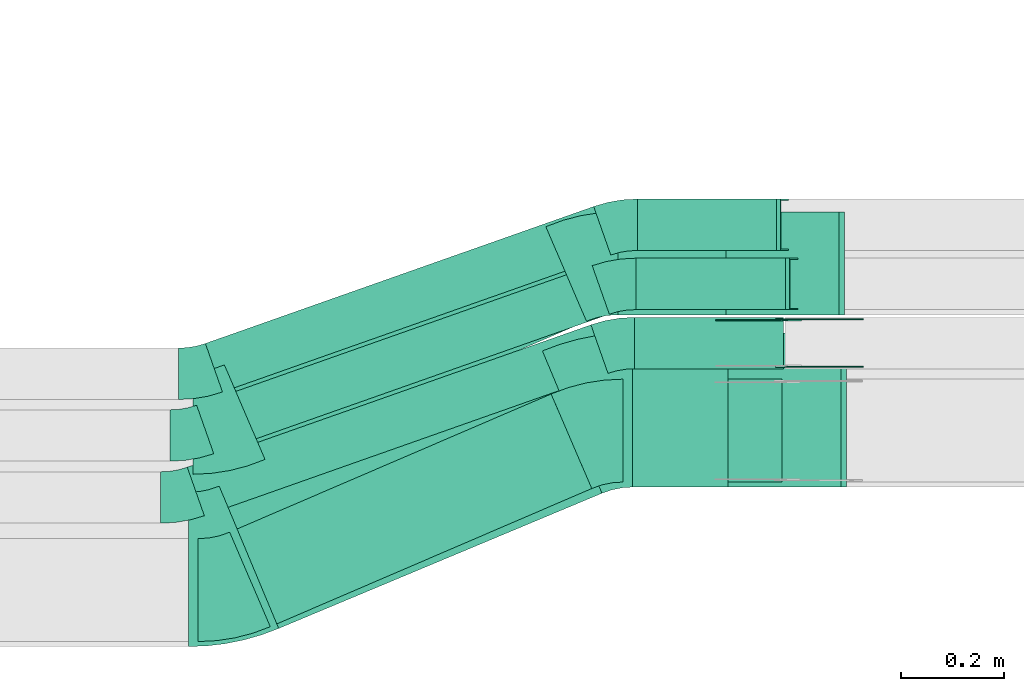
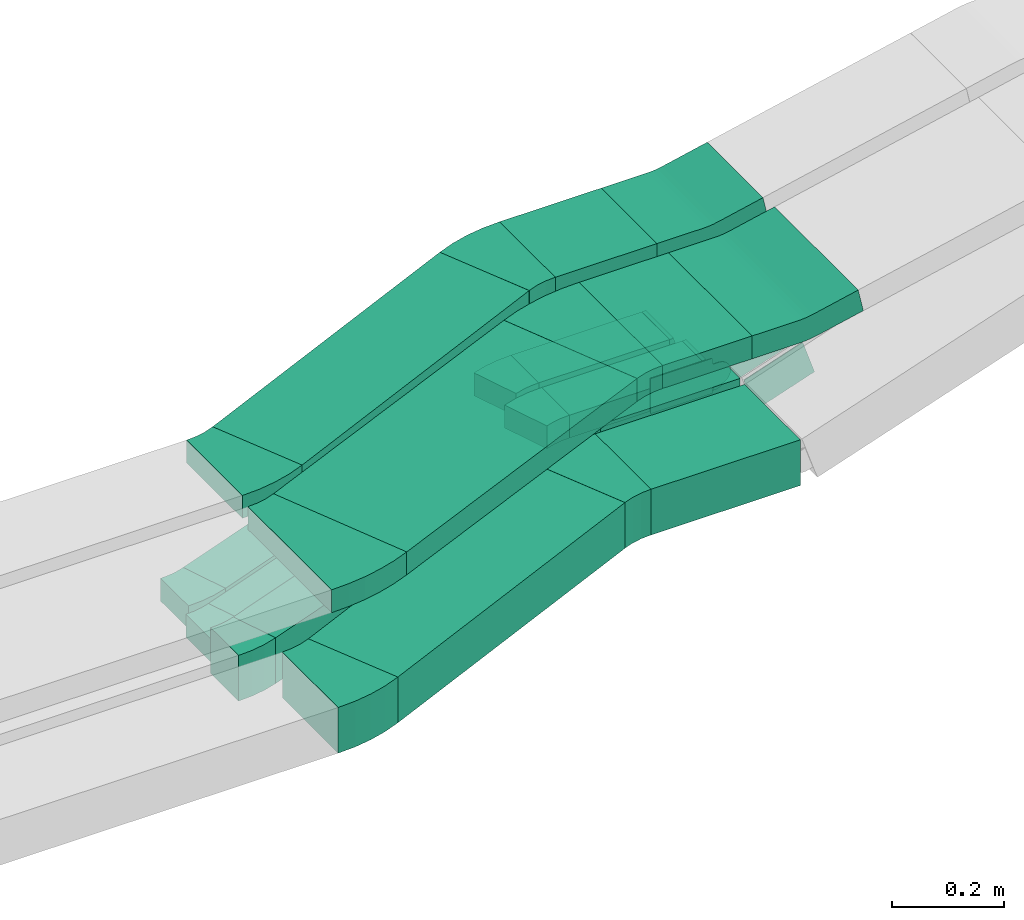
# One storey, part 9 of 28: 19 flow fittings, 12 flow segments.
"""IFC2X3 building model written with IfcOpenShell, lengths in millimetres."""

from ifc_helpers import new_model, entity, si_unit, converted_unit, derived_unit, direction, frame, frame_2d, origin, origin_2d_with_axis, place, context, subcontext, project, spatial, polyline, circle_curve, parameter, trimmed, segment, composite_curve, rectangle, outline, extrude, faceted_brep, source, transform, mapped, material, type_object, type_shapes, element, save


model = new_model("IFC2X3")

# Units and contexts
model_context = context("Model", 3, precision=0.01, world=origin(), true_north=direction((6.12303176911189e-17, 1.0)))
body_context = subcontext(model_context, "Body", "Model", "MODEL_VIEW")
ifc_project = project(units=[si_unit("LENGTHUNIT", "METRE", prefix="MILLI"), si_unit("AREAUNIT", "SQUARE_METRE"), si_unit("VOLUMEUNIT", "CUBIC_METRE"), converted_unit("PLANEANGLEUNIT", "DEGREE", entity("IfcRatioMeasure", 0.0174532925199433), si_unit("PLANEANGLEUNIT", "RADIAN"), dimensions=[0, 0, 0, 0, 0, 0, 0]), si_unit("MASSUNIT", "GRAM", prefix="KILO"), derived_unit("MASSDENSITYUNIT", [(si_unit("MASSUNIT", "GRAM", prefix="KILO"), 1), (si_unit("LENGTHUNIT", "METRE"), -3)]), derived_unit("MOMENTOFINERTIAUNIT", [(si_unit("LENGTHUNIT", "METRE"), 4)]), si_unit("TIMEUNIT", "SECOND"), si_unit("FREQUENCYUNIT", "HERTZ"), si_unit("THERMODYNAMICTEMPERATUREUNIT", "DEGREE_CELSIUS"), derived_unit("THERMALTRANSMITTANCEUNIT", [(si_unit("MASSUNIT", "GRAM", prefix="KILO"), 1), (si_unit("THERMODYNAMICTEMPERATUREUNIT", "KELVIN"), -1), (si_unit("TIMEUNIT", "SECOND"), -3)]), derived_unit("VOLUMETRICFLOWRATEUNIT", [(si_unit("LENGTHUNIT", "METRE"), 3), (si_unit("TIMEUNIT", "SECOND"), -1)]), derived_unit("MASSFLOWRATEUNIT", [(si_unit("MASSUNIT", "GRAM", prefix="KILO"), 1), (si_unit("TIMEUNIT", "SECOND"), -1)]), derived_unit("ROTATIONALFREQUENCYUNIT", [(si_unit("TIMEUNIT", "SECOND"), -1)]), si_unit("ELECTRICCURRENTUNIT", "AMPERE"), si_unit("ELECTRICVOLTAGEUNIT", "VOLT"), si_unit("POWERUNIT", "WATT"), si_unit("FORCEUNIT", "NEWTON", prefix="KILO"), si_unit("ILLUMINANCEUNIT", "LUX"), si_unit("LUMINOUSFLUXUNIT", "LUMEN"), si_unit("LUMINOUSINTENSITYUNIT", "CANDELA"), derived_unit("USERDEFINED", [(si_unit("MASSUNIT", "GRAM", prefix="KILO"), -1), (si_unit("LENGTHUNIT", "METRE"), -2), (si_unit("TIMEUNIT", "SECOND"), 3), (si_unit("LUMINOUSFLUXUNIT", "LUMEN"), 1)]), derived_unit("LINEARVELOCITYUNIT", [(si_unit("LENGTHUNIT", "METRE"), 1), (si_unit("TIMEUNIT", "SECOND"), -1)]), si_unit("PRESSUREUNIT", "PASCAL"), derived_unit("USERDEFINED", [(si_unit("LENGTHUNIT", "METRE"), -2), (si_unit("MASSUNIT", "GRAM", prefix="KILO"), 1), (si_unit("TIMEUNIT", "SECOND"), -2)]), derived_unit("LINEARFORCEUNIT", [(si_unit("MASSUNIT", "GRAM", prefix="KILO"), 1), (si_unit("LENGTHUNIT", "METRE"), 1), (si_unit("TIMEUNIT", "SECOND"), -2), (si_unit("LENGTHUNIT", "METRE"), -1)]), derived_unit("PLANARFORCEUNIT", [(si_unit("MASSUNIT", "GRAM", prefix="KILO"), 1), (si_unit("LENGTHUNIT", "METRE"), 1), (si_unit("TIMEUNIT", "SECOND"), -2), (si_unit("LENGTHUNIT", "METRE"), -2)])], contexts=[model_context])

# Site, building, storey
site_placement = place(None, origin())
site = spatial("IfcSite", under=ifc_project, at=site_placement, CompositionType="ELEMENT")
building_placement = place(site_placement, origin())
building = spatial("IfcBuilding", under=site, at=building_placement, CompositionType="ELEMENT")
storey_placement = place(building_placement, frame((0.0, 0.0, 15900.0)))
storey = spatial("IfcBuildingStorey", under=building, at=storey_placement, CompositionType="ELEMENT", Elevation=15900.0)

# Flow segments
cable_carrier_segment_type = type_object("IfcCableCarrierSegmentType", PredefinedType="CABLETRAYSEGMENT")
flow_segment_1_placement = place(storey_placement, frame((33944.91, 8534.97, 2500.0)))
element("IfcFlowSegment", 1, at=flow_segment_1_placement, inside=storey, type_object=cable_carrier_segment_type, context=body_context, shape_type="SweptSolid", body=[
    extrude(rectangle(XDim=308.884576377895, YDim=200.0, at=origin_2d_with_axis()), frame((154.44, 100.0, 0.0), z_axis=(0.0, 0.0, 1.0), x_axis=(-1.0, 0.0, 0.0)), (0.0, 0.0, 1.0), 100.000000000001),
])
flow_segment_2_placement = place(storey_placement, frame((33934.64, 8860.15, 2820.0)))
element("IfcFlowSegment", 2, at=flow_segment_2_placement, inside=storey, type_object=cable_carrier_segment_type, context=body_context, shape_type="SweptSolid", body=[
    extrude(rectangle(XDim=210.233507475594, YDim=200.0, at=origin_2d_with_axis()), frame((105.12, 100.0, 0.0), z_axis=(0.0, 0.0, 1.0), x_axis=(-1.0, 0.0, 0.0)), (0.0, 0.0, 1.0), 50.0000000000016),
])
flow_segment_3_placement = place(storey_placement, frame((33963.4, 8525.15, 2820.0)))
element("IfcFlowSegment", 3, at=flow_segment_3_placement, inside=storey, type_object=cable_carrier_segment_type, context=body_context, shape_type="SweptSolid", body=[
    extrude(rectangle(XDim=185.088523437471, YDim=300.000000000001, at=origin_2d_with_axis()), frame((92.54, 150.0, 0.0), z_axis=(0.0, 0.0, 1.0), x_axis=(-1.0, 0.0, 0.0)), (0.0, 0.0, 1.0), 50.0000000000016),
])
flow_segment_4_placement = place(storey_placement, frame((33179.89, 8253.8, 2500.0)))
element("IfcFlowSegment", 4, at=flow_segment_4_placement, inside=storey, type_object=cable_carrier_segment_type, context=body_context, shape_type="SweptSolid", body=[
    extrude(rectangle(XDim=680.16852764096, YDim=200.000000000003, at=origin_2d_with_axis()), frame((351.93, 226.16, 0.0), z_axis=(0.0, 0.0, 1.0), x_axis=(0.918736709350663, 0.394870686290481, 0.0)), (0.0, 0.0, 1.0), 99.9999999999989),
])
flow_segment_5_placement = place(storey_placement, frame((33169.62, 8578.99, 2820.0)))
element("IfcFlowSegment", 5, at=flow_segment_5_placement, inside=storey, type_object=cable_carrier_segment_type, context=body_context, shape_type="SweptSolid", body=[
    extrude(rectangle(XDim=680.168527640881, YDim=200.000000000004, at=origin_2d_with_axis()), frame((351.93, 226.16, 0.0), z_axis=(0.0, 0.0, 1.0), x_axis=(0.918736709350649, 0.394870686290513, 0.0)), (0.0, 0.0, 1.0), 50.0000000000016),
])
flow_segment_6_placement = place(storey_placement, frame((33159.52, 8250.38, 2820.0)))
element("IfcFlowSegment", 6, at=flow_segment_6_placement, inside=storey, type_object=cable_carrier_segment_type, context=body_context, shape_type="SweptSolid", body=[
    extrude(rectangle(XDim=681.07290656697, YDim=300.0, at=origin_2d_with_axis()), frame((372.04, 269.77, 0.0), z_axis=(0.0, 0.0, 1.0), x_axis=(0.922573514016603, 0.385821346266711, 0.0)), (0.0, 0.0, 1.0), 50.0000000000016),
])
flow_segment_7_placement = place(storey_placement, frame((33132.68, 8710.07, 2500.0)))
element("IfcFlowSegment", 7, at=flow_segment_7_placement, inside=storey, type_object=cable_carrier_segment_type, context=body_context, shape_type="SweptSolid", body=[
    extrude(rectangle(XDim=800.344538509501, YDim=99.9999999999954, at=origin_2d_with_axis()), frame((394.02, 180.26, 0.0), z_axis=(0.0, 0.0, 1.0), x_axis=(-0.943062738741533, -0.332614898640031, 0.0)), (0.0, 0.0, 1.0), 50.0000000000016),
])
flow_segment_8_placement = place(storey_placement, frame((33115.71, 8590.07, 2500.0)))
element("IfcFlowSegment", 8, at=flow_segment_8_placement, inside=storey, type_object=cable_carrier_segment_type, context=body_context, shape_type="SweptSolid", body=[
    extrude(rectangle(XDim=815.376937901308, YDim=99.9999999999954, at=origin_2d_with_axis()), frame((401.11, 182.76, 0.0), z_axis=(0.0, 0.0, 1.0), x_axis=(0.943062738741534, 0.33261489864003, 0.0)), (0.0, 0.0, 1.0), 50.0000000000016),
])
flow_segment_9_placement = place(storey_placement, frame((33969.76, 8870.15, 2500.0)))
element("IfcFlowSegment", 9, at=flow_segment_9_placement, inside=storey, type_object=cable_carrier_segment_type, context=body_context, shape_type="SweptSolid", body=[
    extrude(rectangle(XDim=290.539792942886, YDim=100.000000000001, at=origin_2d_with_axis()), frame((145.27, 50.0, 0.0), z_axis=(0.0, 0.0, 1.0), x_axis=(-1.0, 0.0, 0.0)), (0.0, 0.0, 1.0), 50.0000000000016),
])
flow_segment_10_placement = place(storey_placement, frame((33097.44, 8469.53, 2500.0)))
element("IfcFlowSegment", 10, at=flow_segment_10_placement, inside=storey, type_object=cable_carrier_segment_type, context=body_context, shape_type="SweptSolid", body=[
    extrude(rectangle(XDim=832.020536746304, YDim=100.0, at=origin_2d_with_axis()), frame((408.95, 185.52, 0.0), z_axis=(0.0, 0.0, 1.0), x_axis=(0.943062738741517, 0.332614898640078, 0.0)), (0.0, 0.0, 1.0), 99.9999999999989),
])
flow_segment_11_placement = place(storey_placement, frame((33967.19, 8755.15, 2500.0)))
element("IfcFlowSegment", 11, at=flow_segment_11_placement, inside=storey, type_object=cable_carrier_segment_type, context=body_context, shape_type="SweptSolid", body=[
    extrude(rectangle(XDim=288.884576377908, YDim=100.000000000001, at=origin_2d_with_axis()), frame((144.44, 50.0, 0.0), z_axis=(0.0, 0.0, 1.0), x_axis=(-1.0, 0.0, 0.0)), (0.0, 0.0, 1.0), 99.9999999999989),
])
flow_segment_12_placement = place(storey_placement, frame((33972.55, 8985.15, 2500.0)))
element("IfcFlowSegment", 12, at=flow_segment_12_placement, inside=storey, type_object=cable_carrier_segment_type, context=body_context, shape_type="SweptSolid", body=[
    extrude(rectangle(XDim=270.781498461428, YDim=99.9999999999989, at=origin_2d_with_axis()), frame((135.39, 50.0, 0.0)), (0.0, 0.0, 1.0), 50.0000000000038),
])

# Flow fittings
ifc_material_1 = material()
cable_carrier_fitting_type_1 = type_object("IfcCableCarrierFittingType", PredefinedType="NOTDEFINED", material=ifc_material_1)
shared_shape_1 = source(origin(), body_context, "Body", "Brep", [
    faceted_brep([(-8.19, 25.0, 50.0), (-8.19, 25.0, -50.0), (-8.19, -25.0, -50.0), (-8.19, -25.0, -47.46), (-8.19, 22.46, -47.46), (-8.19, 22.46, 47.46), (-8.19, -25.0, 47.46), (-8.19, -25.0, 50.0), (-0.21, 26.31, 50.0), (15.74, -21.08, 50.0), (15.74, -21.08, 47.46), (0.6, 23.9, 47.46), (0.6, 23.9, -47.46), (15.74, -21.08, -47.46), (15.74, -21.08, -50.0), (-0.21, 26.31, -50.0), (-4.1, 25.0, 50.0), (-4.1, 25.0, -50.0), (4.1, -25.0, -50.0), (4.1, -25.0, -47.46), (-3.68, 22.46, -47.46), (-3.68, 22.46, 47.46), (4.1, -25.0, 47.46), (4.1, -25.0, 50.0)], [[[0, 1, 2, 3, 4, 5, 6, 7]], [[8, 9, 10, 11, 12, 13, 14, 15]], [[1, 0, 16, 17]], [[2, 1, 17, 15, 14, 18]], [[3, 2, 18, 19]], [[4, 3, 19, 13, 12, 20]], [[5, 4, 20, 21]], [[6, 5, 21, 11, 10, 22]], [[7, 6, 22, 23]], [[0, 7, 23, 9, 8, 16]], [[17, 16, 8, 15]], [[19, 18, 14, 13]], [[21, 20, 12, 11]], [[23, 22, 10, 9]]]),
])
type_shapes(cable_carrier_fitting_type_1, [shared_shape_1])
flow_fitting_1_placement = place(storey_placement, frame((34268.49, 8920.15, 2525.0), z_axis=(0.0, -1.0, 0.0), x_axis=(1.0, 0.0, 0.0)))
element("IfcFlowFitting", 13, at=flow_fitting_1_placement, inside=storey, type_object=cable_carrier_fitting_type_1, material=ifc_material_1, context=body_context, shape_type="MappedRepresentation", body=[
    mapped(shared_shape_1, transform((0.0, 0.0, 0.0), scale=1.0)),
])
cable_carrier_fitting_type_2 = type_object("IfcCableCarrierFittingType", PredefinedType="NOTDEFINED", material=ifc_material_1)
shared_shape_2 = source(origin(), body_context, "Body", "Brep", [
    faceted_brep([(-7.95, 25.0, 50.0), (-7.95, 25.0, -50.0), (-7.95, -25.0, -50.0), (-7.95, -25.0, -47.46), (-7.95, 22.46, -47.46), (-7.95, 22.46, 47.46), (-7.95, -25.0, 47.46), (-7.95, -25.0, 50.0), (-0.2, 26.23, 50.0), (15.31, -21.3, 50.0), (15.31, -21.3, 47.46), (0.59, 23.82, 47.46), (0.59, 23.82, -47.46), (15.31, -21.3, -47.46), (15.31, -21.3, -50.0), (-0.2, 26.23, -50.0), (-3.97, 25.0, 50.0), (-3.97, 25.0, -50.0), (3.97, -25.0, -50.0), (3.97, -25.0, -47.46), (-3.57, 22.46, -47.46), (-3.57, 22.46, 47.46), (3.97, -25.0, 47.46), (3.97, -25.0, 50.0)], [[[0, 1, 2, 3, 4, 5, 6, 7]], [[8, 9, 10, 11, 12, 13, 14, 15]], [[1, 0, 16, 17]], [[2, 1, 17, 15, 14, 18]], [[3, 2, 18, 19]], [[4, 3, 19, 13, 12, 20]], [[5, 4, 20, 21]], [[6, 5, 21, 11, 10, 22]], [[7, 6, 22, 23]], [[0, 7, 23, 9, 8, 16]], [[17, 16, 8, 15]], [[19, 18, 14, 13]], [[21, 20, 12, 11]], [[23, 22, 10, 9]]]),
])
type_shapes(cable_carrier_fitting_type_2, [shared_shape_2])
flow_fitting_2_placement = place(storey_placement, frame((34251.28, 9035.15, 2525.0), z_axis=(0.0, -1.0, 0.0), x_axis=(1.0, 0.0, 0.0)))
element("IfcFlowFitting", 14, at=flow_fitting_2_placement, inside=storey, type_object=cable_carrier_fitting_type_2, material=ifc_material_1, context=body_context, shape_type="MappedRepresentation", body=[
    mapped(shared_shape_2, transform((0.0, 0.0, 0.0), scale=1.0)),
])
cable_carrier_fitting_type_3 = type_object("IfcCableCarrierFittingType", Name="470_DKC_S5_Variable Angle Elbow 0-45:-", PredefinedType="NOTDEFINED", material=ifc_material_1)
shared_shape_3 = source(origin(), body_context, "Body", "SweptSolid", [
    extrude(outline(composite_curve([segment(polyline([(-50.34, -110.26), (-49.34, -110.26)]), True, "CONTINUOUS"), segment(trimmed(circle_curve(frame_2d((-49.34, 239.74), x_axis=(0.0, -1.0)), 350.0), [parameter(0.0)], [parameter(23.2579093419499)], True, "PARAMETER"), True, "CONTINUOUS"), segment(polyline([(88.87, -81.81), (89.78, -81.42)]), True, "CONTINUOUS"), segment(polyline([(89.78, -81.42), (10.81, 102.33)]), True, "CONTINUOUS"), segment(polyline([(10.81, 102.33), (9.89, 101.93)]), True, "CONTINUOUS"), segment(trimmed(circle_curve(frame_2d((-49.34, 239.74), x_axis=(0.0, -1.0)), 150.0), [parameter(0.0)], [parameter(23.2579093419499)], True, "PARAMETER"), False, "CONTINUOUS"), segment(polyline([(-49.34, 89.74), (-50.34, 89.74)]), True, "CONTINUOUS"), segment(polyline([(-50.34, 89.74), (-50.34, -110.26)]), True, "CONTINUOUS")], self_intersect=False)), frame((-2.11, 10.26, -50.0)), (0.0, 0.0, 1.0), 100.0),
])
type_shapes(cable_carrier_fitting_type_3, [shared_shape_3])
flow_fitting_3_placement = place(storey_placement, frame((33171.19, 8324.97, 2550.0)))
element("IfcFlowFitting", 15, at=flow_fitting_3_placement, inside=storey, type_object=cable_carrier_fitting_type_3, material=ifc_material_1, Name="470_DKC_S5_Variable Angle Elbow 0-45:-", ObjectType="470_DKC_S5_Variable Angle Elbow 0-45:-", context=body_context, shape_type="MappedRepresentation", body=[
    mapped(shared_shape_3, transform((0.0, 0.0, 0.0), scale=1.0)),
])
flow_fitting_4_placement = place(storey_placement, frame((33892.46, 8634.97, 2550.0), z_axis=(0.0, 0.0, 1.0), x_axis=(-1.0, 0.0, 0.0)))
element("IfcFlowFitting", 16, at=flow_fitting_4_placement, inside=storey, type_object=cable_carrier_fitting_type_3, material=ifc_material_1, Name="470_DKC_S5_Variable Angle Elbow 0-45:-", ObjectType="470_DKC_S5_Variable Angle Elbow 0-45:-", context=body_context, shape_type="MappedRepresentation", body=[
    mapped(shared_shape_3, transform((0.0, 0.0, 0.0), scale=1.0)),
])
cable_carrier_fitting_type_4 = type_object("IfcCableCarrierFittingType", Name="470_DKC_S5_Variable Angle Elbow 0-45:-", PredefinedType="NOTDEFINED", material=ifc_material_1)
shared_shape_4 = source(origin(), body_context, "Body", "SweptSolid", [
    extrude(outline(composite_curve([segment(polyline([(-50.34, -110.26), (-49.34, -110.26)]), True, "CONTINUOUS"), segment(trimmed(circle_curve(frame_2d((-49.34, 239.74), x_axis=(0.0, -1.0)), 350.0), [parameter(0.0)], [parameter(23.2579093419518)], True, "PARAMETER"), True, "CONTINUOUS"), segment(polyline([(88.87, -81.81), (89.78, -81.42)]), True, "CONTINUOUS"), segment(polyline([(89.78, -81.42), (10.81, 102.33)]), True, "CONTINUOUS"), segment(polyline([(10.81, 102.33), (9.89, 101.93)]), True, "CONTINUOUS"), segment(trimmed(circle_curve(frame_2d((-49.34, 239.74), x_axis=(0.0, -1.0)), 150.0), [parameter(0.0)], [parameter(23.2579093419518)], True, "PARAMETER"), False, "CONTINUOUS"), segment(polyline([(-49.34, 89.74), (-50.34, 89.74)]), True, "CONTINUOUS"), segment(polyline([(-50.34, 89.74), (-50.34, -110.26)]), True, "CONTINUOUS")], self_intersect=False)), frame((-2.11, 10.26, -25.0)), (0.0, 0.0, 1.0), 50.0000000000006),
])
type_shapes(cable_carrier_fitting_type_4, [shared_shape_4])
flow_fitting_5_placement = place(storey_placement, frame((33160.92, 8650.15, 2845.0)))
element("IfcFlowFitting", 17, at=flow_fitting_5_placement, inside=storey, type_object=cable_carrier_fitting_type_4, material=ifc_material_1, Name="470_DKC_S5_Variable Angle Elbow 0-45:-", ObjectType="470_DKC_S5_Variable Angle Elbow 0-45:-", context=body_context, shape_type="MappedRepresentation", body=[
    mapped(shared_shape_4, transform((0.0, 0.0, 0.0), scale=1.0)),
])
flow_fitting_6_placement = place(storey_placement, frame((33882.19, 8960.15, 2845.0), z_axis=(0.0, 0.0, 1.0), x_axis=(-1.0, 0.0, 0.0)))
element("IfcFlowFitting", 18, at=flow_fitting_6_placement, inside=storey, type_object=cable_carrier_fitting_type_4, material=ifc_material_1, Name="470_DKC_S5_Variable Angle Elbow 0-45:-", ObjectType="470_DKC_S5_Variable Angle Elbow 0-45:-", context=body_context, shape_type="MappedRepresentation", body=[
    mapped(shared_shape_4, transform((0.0, 0.0, 0.0), scale=1.0)),
])
cable_carrier_fitting_type_5 = type_object("IfcCableCarrierFittingType", Name="470_DKC_S5_Variable Angle Elbow 0-45:-", PredefinedType="NOTDEFINED", material=ifc_material_1)
shared_shape_5 = source(origin(), body_context, "Body", "SweptSolid", [
    extrude(outline(composite_curve([segment(polyline([(-58.85, -161.71), (-57.85, -161.71)]), True, "CONTINUOUS"), segment(trimmed(circle_curve(frame_2d((-57.85, 288.29), x_axis=(0.0, -1.0)), 450.0), [parameter(0.0)], [parameter(22.6947399098988)], True, "PARAMETER"), True, "CONTINUOUS"), segment(polyline([(115.77, -126.87), (116.69, -126.48)]), True, "CONTINUOUS"), segment(polyline([(116.69, -126.48), (0.94, 150.29)]), True, "CONTINUOUS"), segment(polyline([(0.94, 150.29), (0.02, 149.9)]), True, "CONTINUOUS"), segment(trimmed(circle_curve(frame_2d((-57.85, 288.29), x_axis=(0.0, -1.0)), 150.0), [parameter(0.0)], [parameter(22.6947399098988)], True, "PARAMETER"), False, "CONTINUOUS"), segment(polyline([(-57.85, 138.29), (-58.85, 138.29)]), True, "CONTINUOUS"), segment(polyline([(-58.85, 138.29), (-58.85, -161.71)]), True, "CONTINUOUS")], self_intersect=False)), frame((-2.35, 11.71, -25.0)), (0.0, 0.0, 1.0), 49.9999999999992),
])
type_shapes(cable_carrier_fitting_type_5, [shared_shape_5])
flow_fitting_7_placement = place(storey_placement, frame((33160.92, 8365.15, 2845.0)))
element("IfcFlowFitting", 19, at=flow_fitting_7_placement, inside=storey, type_object=cable_carrier_fitting_type_5, material=ifc_material_1, Name="470_DKC_S5_Variable Angle Elbow 0-45:-", ObjectType="470_DKC_S5_Variable Angle Elbow 0-45:-", context=body_context, shape_type="MappedRepresentation", body=[
    mapped(shared_shape_5, transform((0.0, 0.0, 0.0), scale=1.0)),
])
flow_fitting_8_placement = place(storey_placement, frame((33902.19, 8675.15, 2845.0), z_axis=(0.0, 0.0, 1.0), x_axis=(-1.0, 0.0, 0.0)))
element("IfcFlowFitting", 20, at=flow_fitting_8_placement, inside=storey, type_object=cable_carrier_fitting_type_5, material=ifc_material_1, Name="470_DKC_S5_Variable Angle Elbow 0-45:-", ObjectType="470_DKC_S5_Variable Angle Elbow 0-45:-", context=body_context, shape_type="MappedRepresentation", body=[
    mapped(shared_shape_5, transform((0.0, 0.0, 0.0), scale=1.0)),
])
cable_carrier_fitting_type_6 = type_object("IfcCableCarrierFittingType", Name="470_DKC_S5_Variable Angle Elbow 0-45:-", PredefinedType="NOTDEFINED", material=ifc_material_1)
shared_shape_6 = source(origin(), body_context, "Body", "SweptSolid", [
    extrude(outline(composite_curve([segment(polyline([(-34.25, -55.78), (-33.25, -55.78)]), True, "CONTINUOUS"), segment(trimmed(circle_curve(frame_2d((-33.25, 194.22), x_axis=(0.0, -1.0)), 250.0), [parameter(0.0)], [parameter(19.4275662628412)], True, "PARAMETER"), True, "CONTINUOUS"), segment(polyline([(49.91, -41.54), (50.85, -41.21)]), True, "CONTINUOUS"), segment(polyline([(50.85, -41.21), (17.59, 53.1)]), True, "CONTINUOUS"), segment(polyline([(17.59, 53.1), (16.64, 52.76)]), True, "CONTINUOUS"), segment(trimmed(circle_curve(frame_2d((-33.25, 194.22), x_axis=(0.0, -1.0)), 150.0), [parameter(0.0)], [parameter(19.4275662628412)], True, "PARAMETER"), False, "CONTINUOUS"), segment(polyline([(-33.25, 44.22), (-34.25, 44.22)]), True, "CONTINUOUS"), segment(polyline([(-34.25, 44.22), (-34.25, -55.78)]), True, "CONTINUOUS")], self_intersect=False)), frame((-0.99, 5.78, -25.0)), (0.0, 0.0, 1.0), 50.0000000000001),
])
type_shapes(cable_carrier_fitting_type_6, [shared_shape_6])
flow_fitting_9_placement = place(storey_placement, frame((33937.31, 9035.15, 2525.0), z_axis=(0.0, 0.0, 1.0), x_axis=(-1.0, 0.0, 0.0)))
element("IfcFlowFitting", 21, at=flow_fitting_9_placement, inside=storey, type_object=cable_carrier_fitting_type_6, material=ifc_material_1, Name="470_DKC_S5_Variable Angle Elbow 0-45:-", ObjectType="470_DKC_S5_Variable Angle Elbow 0-45:-", context=body_context, shape_type="MappedRepresentation", body=[
    mapped(shared_shape_6, transform((0.0, 0.0, 0.0), scale=1.0)),
])
for number, where, name in (
    (22, (33116.08, 8745.5, 2525.0), "470_DKC_S5_Variable Angle Elbow 0-45:-"),
    (23, (33099.11, 8625.5, 2525.0), "470_DKC_S5_Variable Angle Elbow 0-45:-"),
):
    element("IfcFlowFitting", number, at=place(storey_placement, frame(where)), inside=storey, type_object=cable_carrier_fitting_type_6, material=ifc_material_1, Name=name, ObjectType="470_DKC_S5_Variable Angle Elbow 0-45:-", context=body_context, shape_type="MappedRepresentation", body=[
        mapped(shared_shape_6, transform((0.0, 0.0, 0.0), scale=1.0)),
    ])
flow_fitting_10_placement = place(storey_placement, frame((33934.52, 8920.15, 2525.0), z_axis=(0.0, 0.0, 1.0), x_axis=(-1.0, 0.0, 0.0)))
element("IfcFlowFitting", 24, at=flow_fitting_10_placement, inside=storey, type_object=cable_carrier_fitting_type_6, material=ifc_material_1, Name="470_DKC_S5_Variable Angle Elbow 0-45:-", ObjectType="470_DKC_S5_Variable Angle Elbow 0-45:-", context=body_context, shape_type="MappedRepresentation", body=[
    mapped(shared_shape_6, transform((0.0, 0.0, 0.0), scale=1.0)),
])
cable_carrier_fitting_type_7 = type_object("IfcCableCarrierFittingType", Name="470_DKC_S5_Variable Angle Elbow 0-45:-", PredefinedType="NOTDEFINED", material=ifc_material_1)
shared_shape_7 = source(origin(), body_context, "Body", "SweptSolid", [
    extrude(outline(composite_curve([segment(polyline([(-34.25, -55.78), (-33.25, -55.78)]), True, "CONTINUOUS"), segment(trimmed(circle_curve(frame_2d((-33.25, 194.22), x_axis=(0.0, -1.0)), 250.0), [parameter(0.0)], [parameter(19.4275662628425)], True, "PARAMETER"), True, "CONTINUOUS"), segment(polyline([(49.91, -41.54), (50.85, -41.21)]), True, "CONTINUOUS"), segment(polyline([(50.85, -41.21), (17.59, 53.1)]), True, "CONTINUOUS"), segment(polyline([(17.59, 53.1), (16.64, 52.76)]), True, "CONTINUOUS"), segment(trimmed(circle_curve(frame_2d((-33.25, 194.22), x_axis=(0.0, -1.0)), 150.0), [parameter(0.0)], [parameter(19.4275662628425)], True, "PARAMETER"), False, "CONTINUOUS"), segment(polyline([(-33.25, 44.22), (-34.25, 44.22)]), True, "CONTINUOUS"), segment(polyline([(-34.25, 44.22), (-34.25, -55.78)]), True, "CONTINUOUS")], self_intersect=False)), frame((-0.99, 5.78, -50.0)), (0.0, 0.0, 1.0), 100.0),
])
type_shapes(cable_carrier_fitting_type_7, [shared_shape_7])
flow_fitting_11_placement = place(storey_placement, frame((33080.84, 8504.97, 2550.0)))
element("IfcFlowFitting", 25, at=flow_fitting_11_placement, inside=storey, type_object=cable_carrier_fitting_type_7, material=ifc_material_1, Name="470_DKC_S5_Variable Angle Elbow 0-45:-", ObjectType="470_DKC_S5_Variable Angle Elbow 0-45:-", context=body_context, shape_type="MappedRepresentation", body=[
    mapped(shared_shape_7, transform((0.0, 0.0, 0.0), scale=1.0)),
])
flow_fitting_12_placement = place(storey_placement, frame((33931.95, 8805.15, 2550.0), z_axis=(0.0, 0.0, 1.0), x_axis=(-1.0, 0.0, 0.0)))
element("IfcFlowFitting", 26, at=flow_fitting_12_placement, inside=storey, type_object=cable_carrier_fitting_type_7, material=ifc_material_1, Name="470_DKC_S5_Variable Angle Elbow 0-45:-", ObjectType="470_DKC_S5_Variable Angle Elbow 0-45:-", context=body_context, shape_type="MappedRepresentation", body=[
    mapped(shared_shape_7, transform((0.0, 0.0, 0.0), scale=1.0)),
])
cable_carrier_fitting_type_8 = type_object("IfcCableCarrierFittingType", Name="470_DKC_S5_CD 90 external vertical angle:-", PredefinedType="NOTDEFINED", material=ifc_material_1)
shared_shape_8 = source(origin(), body_context, "Body", "SweptSolid", [
    extrude(outline(composite_curve([segment(polyline([(-112.89, -31.98), (-16.98, -31.98)]), True, "CONTINUOUS"), segment(trimmed(circle_curve(frame_2d((-16.98, 158.02), x_axis=(0.0, -1.0)), 189.999999999999), [parameter(0.0)], [parameter(12.2682836771792)], True, "PARAMETER"), True, "CONTINUOUS"), segment(polyline([(23.39, -27.64), (117.11, -7.26)]), True, "CONTINUOUS"), segment(polyline([(117.11, -7.26), (106.48, 41.6)]), True, "CONTINUOUS"), segment(polyline([(106.48, 41.6), (12.77, 21.22)]), True, "CONTINUOUS"), segment(trimmed(circle_curve(frame_2d((-16.98, 158.02), x_axis=(0.0, -1.0)), 139.999999999999), [parameter(0.0)], [parameter(12.2682836771792)], True, "PARAMETER"), False, "CONTINUOUS"), segment(polyline([(-16.98, 18.02), (-112.89, 18.02)]), True, "CONTINUOUS"), segment(polyline([(-112.89, 18.02), (-112.89, -31.98)]), True, "CONTINUOUS")], self_intersect=False)), frame((-0.75, 6.98, -150.0)), (0.0, 0.0, 1.0), 300.0),
])
type_shapes(cable_carrier_fitting_type_8, [shared_shape_8])
flow_fitting_13_placement = place(storey_placement, frame((34262.13, 8675.15, 2845.0), z_axis=(0.0, -1.0, 0.0), x_axis=(1.0, 0.0, 0.0)))
element("IfcFlowFitting", 27, at=flow_fitting_13_placement, inside=storey, type_object=cable_carrier_fitting_type_8, material=ifc_material_1, Name="470_DKC_S5_CD 90 external vertical angle:-", ObjectType="470_DKC_S5_CD 90 external vertical angle:-", context=body_context, shape_type="MappedRepresentation", body=[
    mapped(shared_shape_8, transform((0.0, 0.0, 0.0), scale=1.0)),
])
cable_carrier_fitting_type_9 = type_object("IfcCableCarrierFittingType", Name="470_DKC_S5_CD 90 external vertical angle:-", PredefinedType="NOTDEFINED", material=ifc_material_1)
shared_shape_9 = source(origin(), body_context, "Body", "SweptSolid", [
    extrude(outline(composite_curve([segment(polyline([(-112.89, -31.99), (-17.01, -31.99)]), True, "CONTINUOUS"), segment(trimmed(circle_curve(frame_2d((-17.01, 158.01), x_axis=(0.0, -1.0)), 189.999999999999), [parameter(0.0)], [parameter(12.2917958116951)], True, "PARAMETER"), True, "CONTINUOUS"), segment(polyline([(23.44, -27.64), (117.11, -7.23)]), True, "CONTINUOUS"), segment(polyline([(117.11, -7.23), (106.47, 41.63)]), True, "CONTINUOUS"), segment(polyline([(106.47, 41.63), (12.79, 21.22)]), True, "CONTINUOUS"), segment(trimmed(circle_curve(frame_2d((-17.01, 158.01), x_axis=(0.0, -1.0)), 139.999999999999), [parameter(0.0)], [parameter(12.2917958116951)], True, "PARAMETER"), False, "CONTINUOUS"), segment(polyline([(-17.01, 18.01), (-112.89, 18.01)]), True, "CONTINUOUS"), segment(polyline([(-112.89, 18.01), (-112.89, -31.99)]), True, "CONTINUOUS")], self_intersect=False)), frame((-0.75, 6.99, -100.0)), (0.0, 0.0, 1.0), 200.0),
])
type_shapes(cable_carrier_fitting_type_9, [shared_shape_9])
flow_fitting_14_placement = place(storey_placement, frame((34258.52, 8960.15, 2845.0), z_axis=(0.0, -1.0, 0.0), x_axis=(1.0, 0.0, 0.0)))
element("IfcFlowFitting", 28, at=flow_fitting_14_placement, inside=storey, type_object=cable_carrier_fitting_type_9, material=ifc_material_1, Name="470_DKC_S5_CD 90 external vertical angle:-", ObjectType="470_DKC_S5_CD 90 external vertical angle:-", context=body_context, shape_type="MappedRepresentation", body=[
    mapped(shared_shape_9, transform((0.0, 0.0, 0.0), scale=1.0)),
])
ifc_material_2 = material(Name="G")
cable_carrier_fitting_type_10 = type_object("IfcCableCarrierFittingType", PredefinedType="NOTDEFINED", material=ifc_material_2)
shared_shape_10 = source(origin(), body_context, "Body", "SweptSolid", [
    extrude(outline(composite_curve([segment(trimmed(circle_curve(frame_2d((-41.47, 0.0), x_axis=(1.0, 0.0)), 25.0), [parameter(90.0000000000007)], [parameter(270.0)], True, "PARAMETER"), True, "CONTINUOUS"), segment(polyline([(-41.47, -25.0), (-29.97, -25.0)]), True, "CONTINUOUS"), segment(polyline([(-29.97, -25.0), (-28.1, -38.5)]), True, "CONTINUOUS"), segment(polyline([(-28.1, -38.5), (99.53, -38.5)]), True, "CONTINUOUS"), segment(polyline([(99.53, -38.5), (99.53, 38.5)]), True, "CONTINUOUS"), segment(polyline([(99.53, 38.5), (-28.1, 38.5)]), True, "CONTINUOUS"), segment(polyline([(-28.1, 38.5), (-29.97, 25.0)]), True, "CONTINUOUS"), segment(polyline([(-29.97, 25.0), (-41.47, 25.0)]), True, "CONTINUOUS")], self_intersect=False)), frame((41.47, 0.0, 0.0), z_axis=(0.0, 0.0, -1.0), x_axis=(1.0, 0.0, 0.0)), (0.0, 0.0, -1.0), 2.0),
])
type_shapes(cable_carrier_fitting_type_10, [shared_shape_10])
flow_fitting_15_placement = place(storey_placement, frame((34265.92, 8759.69, 2550.0), z_axis=(0.0, -1.0, 0.0), x_axis=(0.947738671950754, 0.0, 0.319047660528989)))
element("IfcFlowFitting", 29, at=flow_fitting_15_placement, inside=storey, type_object=cable_carrier_fitting_type_10, material=ifc_material_2, context=body_context, shape_type="MappedRepresentation", body=[
    mapped(shared_shape_10, transform((0.0, 0.0, 0.0), scale=1.0)),
])
cable_carrier_fitting_type_11 = type_object("IfcCableCarrierFittingType", PredefinedType="NOTDEFINED", material=ifc_material_2)
type_shapes(cable_carrier_fitting_type_11, [shared_shape_10])
flow_fitting_16_placement = place(storey_placement, frame((34265.92, 8848.61, 2550.0), z_axis=(0.0, 1.0, 0.0), x_axis=(-1.0, 0.0, 0.0)))
element("IfcFlowFitting", 30, at=flow_fitting_16_placement, inside=storey, type_object=cable_carrier_fitting_type_11, material=ifc_material_2, context=body_context, shape_type="MappedRepresentation", body=[
    mapped(shared_shape_10, transform((0.0, 0.0, 0.0), scale=1.0)),
])
cable_carrier_fitting_type_12 = type_object("IfcCableCarrierFittingType", PredefinedType="NOTDEFINED", material=ifc_material_2)
shared_shape_11 = source(origin(), body_context, "Body", "SweptSolid", [
    extrude(outline(composite_curve([segment(trimmed(circle_curve(frame_2d((-41.47, 0.0), x_axis=(1.0, 0.0)), 25.0), [parameter(90.0000000000007)], [parameter(270.0)], True, "PARAMETER"), True, "CONTINUOUS"), segment(polyline([(-41.47, -25.0), (-29.97, -25.0)]), True, "CONTINUOUS"), segment(polyline([(-29.97, -25.0), (-28.1, -38.5)]), True, "CONTINUOUS"), segment(polyline([(-28.1, -38.5), (99.53, -38.5)]), True, "CONTINUOUS"), segment(polyline([(99.53, -38.5), (99.53, 38.5)]), True, "CONTINUOUS"), segment(polyline([(99.53, 38.5), (-28.1, 38.5)]), True, "CONTINUOUS"), segment(polyline([(-28.1, 38.5), (-29.97, 25.0)]), True, "CONTINUOUS"), segment(polyline([(-29.97, 25.0), (-41.47, 25.0)]), True, "CONTINUOUS")], self_intersect=False)), frame((41.47, 0.0, 0.0)), (0.0, 0.0, 1.0), 2.0),
])
type_shapes(cable_carrier_fitting_type_12, [shared_shape_11])
flow_fitting_17_placement = place(storey_placement, frame((34265.92, 8850.61, 2550.0), z_axis=(0.0, 1.0, 0.0), x_axis=(0.947738671950754, 0.0, 0.319047660528989)))
element("IfcFlowFitting", 31, at=flow_fitting_17_placement, inside=storey, type_object=cable_carrier_fitting_type_12, material=ifc_material_2, context=body_context, shape_type="MappedRepresentation", body=[
    mapped(shared_shape_11, transform((0.0, 0.0, 0.0), scale=1.0)),
])

save(model, "model.ifc")
